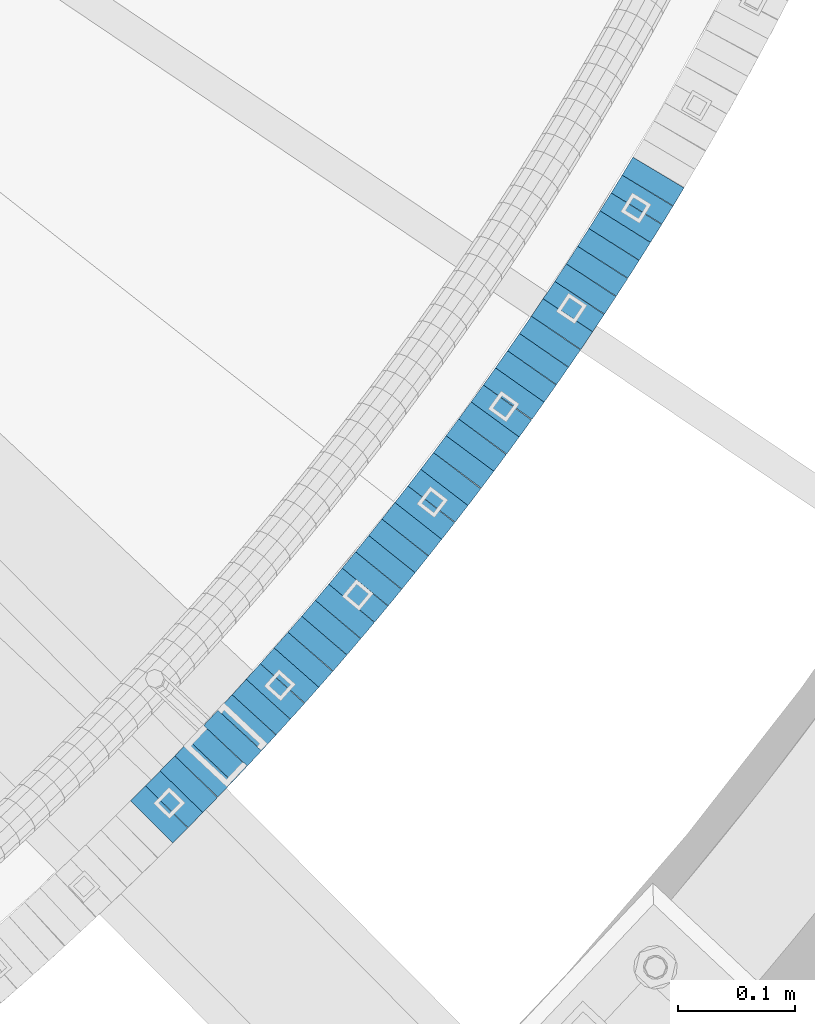
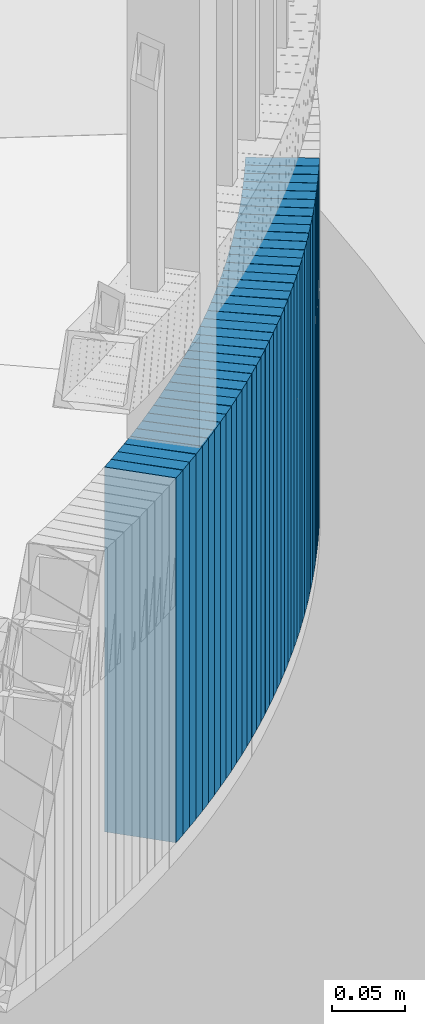
# One storey, part 905 of 975: 39 plates.
"""IFC2X3 building model written with IfcOpenShell, lengths in millimetres."""

from ifc_helpers import new_model, si_unit, frame, origin_with_axes, place, context, subcontext, project, spatial, faceted_brep, material, type_object, element, save


model = new_model("IFC2X3")

# Units and contexts
model_context = context("Model", 3, precision=1e-05, world=origin_with_axes())
body_context = subcontext(model_context, "Body", "Model", "MODEL_VIEW")
ifc_project = project(units=[si_unit("LENGTHUNIT", "METRE", prefix="MILLI"), si_unit("AREAUNIT", "SQUARE_METRE"), si_unit("VOLUMEUNIT", "CUBIC_METRE"), si_unit("MASSUNIT", "GRAM", prefix="KILO"), si_unit("TIMEUNIT", "SECOND"), si_unit("PLANEANGLEUNIT", "RADIAN"), si_unit("SOLIDANGLEUNIT", "STERADIAN"), si_unit("THERMODYNAMICTEMPERATUREUNIT", "DEGREE_CELSIUS"), si_unit("LUMINOUSINTENSITYUNIT", "LUMEN")], contexts=[model_context])

# Site, building, storey
site_placement = place(None, origin_with_axes())
site = spatial("IfcSite", under=ifc_project, at=site_placement, CompositionType="ELEMENT")
building_placement = place(site_placement, origin_with_axes())
building = spatial("IfcBuilding", under=site, at=building_placement, Name="Undefined", CompositionType="ELEMENT")
storey_placement = place(building_placement, origin_with_axes())
storey = spatial("IfcBuildingStorey", under=building, at=storey_placement, Name="Undefined", CompositionType="ELEMENT", Elevation=0.0)

# Plates
ifc_material = material(Name="STEEL/A36")
plate_type = type_object("IfcPlateType", PredefinedType="NOTDEFINED")
plate_1_placement = place(storey_placement, frame((36777.3519568225, 1386.64172835719, 2339.98750006771), z_axis=(-0.707106781186548, -0.707106781186548, 0.0), x_axis=(0.0, 0.0, 1.0)))
element("IfcPlate", 1, at=plate_1_placement, inside=storey, type_object=plate_type, material=ifc_material, Name="WALL", context=body_context, shape_type="Brep", body=[
    faceted_brep([(0.0, -25.3999999999724, -1.81898940354586e-11), (5.69999980926514, -25.3999999999432, 17.8213348388126), (5.69999980926514, 25.3999999999905, 17.8213348388708), (0.0, 25.3999999999869, 1.45519152283669e-11), (310.5, -25.3999999999432, 17.8213348388126), (310.5, 25.3999999999905, 17.8213348388708), (304.799987792969, -25.3999999999724, -1.81898940354586e-11), (304.799987792969, 25.3999999999869, 1.45519152283669e-11)], [[[0, 1, 2, 3]], [[1, 4, 5, 2]], [[4, 6, 7, 5]], [[6, 0, 3, 7]], [[5, 7, 3, 2]], [[6, 4, 1, 0]]]),
])
for number, where, z_axis, x_axis, name in (
    (2, (36790.0636498124, 1399.6559464257, 2334.28750006771), (-0.698672998973502, -0.715441150972862, 0.0), (0.0, 0.0, 1.0), "WALL"),
    (3, (36802.5636498098, 1412.45594642572, 2328.58750006771), (-0.698672998973502, -0.715441150972862, 0.0), (0.0, 0.0, 1.0), "WALL"),
):
    element("IfcPlate", number, at=place(storey_placement, frame(where, z_axis=z_axis, x_axis=x_axis)), inside=storey, type_object=plate_type, material=ifc_material, Name=name, context=body_context, shape_type="Brep", body=[
        faceted_brep([(0.0, -25.3999999999724, -1.81898940354586e-11), (5.69999980926514, -25.3999999999614, 17.8921775817616), (5.69999980926514, 25.400000000016, 17.8921775817726), (0.0, 25.3999999999869, 1.45519152283669e-11), (310.5, -25.3999999999614, 17.8921775817616), (310.5, 25.400000000016, 17.8921775817726), (304.799987792969, -25.3999999999724, -1.81898940354586e-11), (304.799987792969, 25.3999999999869, 1.45519152283669e-11)], [[[0, 1, 2, 3]], [[1, 4, 5, 2]], [[4, 6, 7, 5]], [[6, 0, 3, 7]], [[5, 7, 3, 2]], [[6, 4, 1, 0]]]),
    ])
plate_2_placement = place(storey_placement, frame((36815.0743782141, 1425.57432712152, 2322.78750006771), z_axis=(-0.690075333779924, -0.723737544769184, 0.0), x_axis=(0.0, 0.0, 1.0)))
element("IfcPlate", 4, at=plate_2_placement, inside=storey, type_object=plate_type, material=ifc_material, Name="WALL", context=body_context, shape_type="Brep", body=[
    faceted_brep([(0.0, -25.3999999999724, -1.81898940354586e-11), (5.80000019073486, -25.3999999999869, 17.8241405487097), (5.80000019073486, 25.3999999999432, 17.8241405486515), (0.0, 25.3999999999869, 1.45519152283669e-11), (310.600006103516, -25.3999999999869, 17.8241405487097), (310.600006103516, 25.3999999999432, 17.8241405486515), (304.799987792969, -25.3999999999724, -1.81898940354586e-11), (304.799987792969, 25.3999999999869, 1.45519152283669e-11)], [[[0, 1, 2, 3]], [[1, 4, 5, 2]], [[4, 6, 7, 5]], [[6, 0, 3, 7]], [[5, 7, 3, 2]], [[6, 4, 1, 0]]]),
])
plate_3_placement = place(storey_placement, frame((36827.4418272916, 1438.64534002369, 2317.08750006771), z_axis=(-0.68727955022236, -0.726393020235017, 0.0), x_axis=(0.0, 0.0, 1.0)))
element("IfcPlate", 5, at=plate_3_placement, inside=storey, type_object=plate_type, material=ifc_material, Name="WALL", context=body_context, shape_type="Brep", body=[
    faceted_brep([(0.0, -25.3999999999724, -1.81898940354586e-11), (5.69999980926514, -25.3999999999978, 17.9011173248218), (5.69999980926514, 25.4000000000087, 17.9011173248182), (0.0, 25.3999999999869, 1.45519152283669e-11), (310.5, -25.3999999999978, 17.9011173248218), (310.5, 25.4000000000087, 17.9011173248182), (304.799987792969, -25.3999999999724, -1.81898940354586e-11), (304.799987792969, 25.3999999999869, 1.45519152283669e-11)], [[[0, 1, 2, 3]], [[1, 4, 5, 2]], [[4, 6, 7, 5]], [[6, 0, 3, 7]], [[5, 7, 3, 2]], [[6, 4, 1, 0]]]),
])
plate_4_placement = place(storey_placement, frame((36839.684010914, 1451.79685192806, 2311.38750006771), z_axis=(-0.681314514625853, -0.731990800598025, 0.0), x_axis=(0.0, 0.0, 1.0)))
element("IfcPlate", 6, at=plate_4_placement, inside=storey, type_object=plate_type, material=ifc_material, Name="WALL", context=body_context, shape_type="Brep", body=[
    faceted_brep([(0.0, -25.3999999999724, -1.81898940354586e-11), (5.69999980926514, -25.3999999999542, 17.7609119415029), (5.69999980926514, 25.4000000000051, 17.7609119415283), (0.0, 25.3999999999869, 1.45519152283669e-11), (310.5, -25.3999999999542, 17.7609119415029), (310.5, 25.4000000000051, 17.7609119415283), (304.799987792969, -25.3999999999724, -1.81898940354586e-11), (304.799987792969, 25.3999999999869, 1.45519152283669e-11)], [[[0, 1, 2, 3]], [[1, 4, 5, 2]], [[4, 6, 7, 5]], [[6, 0, 3, 7]], [[5, 7, 3, 2]], [[6, 4, 1, 0]]]),
])
plate_5_placement = place(storey_placement, frame((36851.915159729, 1465.13883502595, 2305.68750006771), z_axis=(-0.675724628879609, -0.737154139868668, 0.0), x_axis=(0.0, 0.0, 1.0)))
element("IfcPlate", 7, at=plate_5_placement, inside=storey, type_object=plate_type, material=ifc_material, Name="WALL", context=body_context, shape_type="Brep", body=[
    faceted_brep([(0.0, -25.3999999999724, -1.81898940354586e-11), (5.69999980926514, -25.4000000000633, 17.9075393677485), (5.69999980926514, 25.3999999999905, 17.9075393676903), (0.0, 25.3999999999869, 1.45519152283669e-11), (310.5, -25.4000000000633, 17.9075393677485), (310.5, 25.3999999999905, 17.9075393676903), (304.799987792969, -25.3999999999724, -1.81898940354586e-11), (304.799987792969, 25.3999999999869, 1.45519152283669e-11)], [[[0, 1, 2, 3]], [[1, 4, 5, 2]], [[4, 6, 7, 5]], [[6, 0, 3, 7]], [[5, 7, 3, 2]], [[6, 4, 1, 0]]]),
])
plate_6_placement = place(storey_placement, frame((36863.9859224343, 1478.41635162711, 2299.88750006771), z_axis=(-0.672672794195408, -0.739940073214948, 0.0), x_axis=(0.0, 0.0, 1.0)))
element("IfcPlate", 8, at=plate_6_placement, inside=storey, type_object=plate_type, material=ifc_material, Name="WALL", context=body_context, shape_type="Brep", body=[
    faceted_brep([(0.0, -25.3999999999724, -1.81898940354586e-11), (5.80000019073486, -25.3999999999614, 17.8392829894583), (5.80000019073486, 25.3999999999578, 17.8392829895529), (0.0, 25.3999999999869, 1.45519152283669e-11), (310.600006103516, -25.3999999999614, 17.8392829894583), (310.600006103516, 25.3999999999578, 17.8392829895529), (304.799987792969, -25.3999999999724, -1.81898940354586e-11), (304.799987792969, 25.3999999999869, 1.45519152283669e-11)], [[[0, 1, 2, 3]], [[1, 4, 5, 2]], [[4, 6, 7, 5]], [[6, 0, 3, 7]], [[5, 7, 3, 2]], [[6, 4, 1, 0]]]),
])
plate_7_placement = place(storey_placement, frame((36876.0499497796, 1491.78704793645, 2294.18750006771), z_axis=(-0.669889474924749, -0.742460834916593, 0.0), x_axis=(0.0, 0.0, 1.0)))
element("IfcPlate", 9, at=plate_7_placement, inside=storey, type_object=plate_type, material=ifc_material, Name="WALL", context=body_context, shape_type="Brep", body=[
    faceted_brep([(0.0, -25.3999999999724, -1.81898940354586e-11), (5.69999980926514, -25.4000000000633, 17.9075393677485), (5.69999980926514, 25.3999999999905, 17.9075393676903), (0.0, 25.3999999999869, 1.45519152283669e-11), (310.5, -25.4000000000633, 17.9075393677485), (310.5, 25.3999999999905, 17.9075393676903), (304.799987792969, -25.3999999999724, -1.81898940354586e-11), (304.799987792969, 25.3999999999869, 1.45519152283669e-11)], [[[0, 1, 2, 3]], [[1, 4, 5, 2]], [[4, 6, 7, 5]], [[6, 0, 3, 7]], [[5, 7, 3, 2]], [[6, 4, 1, 0]]]),
])
plate_8_placement = place(storey_placement, frame((36888.0539227053, 1505.4158792494, 2288.48750006771), z_axis=(-0.660880368115947, -0.750491265131667, 0.0), x_axis=(0.0, 0.0, 1.0)))
element("IfcPlate", 10, at=plate_8_placement, inside=storey, type_object=plate_type, material=ifc_material, Name="WALL", context=body_context, shape_type="Brep", body=[
    faceted_brep([(0.0, -25.3999999999724, -1.81898940354586e-11), (5.69999980926514, -25.4000000000196, 17.8538513183848), (5.69999980926514, 25.4000000000415, 17.8538513183157), (0.0, 25.3999999999869, 1.45519152283669e-11), (310.5, -25.4000000000196, 17.8538513183848), (310.5, 25.4000000000415, 17.8538513183157), (304.799987792969, -25.3999999999724, -1.81898940354586e-11), (304.799987792969, 25.3999999999869, 1.45519152283669e-11)], [[[0, 1, 2, 3]], [[1, 4, 5, 2]], [[4, 6, 7, 5]], [[6, 0, 3, 7]], [[5, 7, 3, 2]], [[6, 4, 1, 0]]]),
])
plate_9_placement = place(storey_placement, frame((36899.8539227035, 1518.81587924938, 2282.68750006771), z_axis=(-0.660880368115947, -0.750491265131667, 0.0), x_axis=(0.0, 0.0, 1.0)))
element("IfcPlate", 11, at=plate_9_placement, inside=storey, type_object=plate_type, material=ifc_material, Name="WALL", context=body_context, shape_type="Brep", body=[
    faceted_brep([(0.0, -25.3999999999724, -1.81898940354586e-11), (5.80000019073486, -25.4000000000306, 17.853010177645), (5.80000019073486, 25.3999999999578, 17.8530101776596), (0.0, 25.3999999999869, 1.45519152283669e-11), (310.600006103516, -25.4000000000306, 17.853010177645), (310.600006103516, 25.3999999999578, 17.8530101776596), (304.799987792969, -25.3999999999724, -1.81898940354586e-11), (304.799987792969, 25.3999999999869, 1.45519152283669e-11)], [[[0, 1, 2, 3]], [[1, 4, 5, 2]], [[4, 6, 7, 5]], [[6, 0, 3, 7]], [[5, 7, 3, 2]], [[6, 4, 1, 0]]]),
])
plate_10_placement = place(storey_placement, frame((36911.7465485518, 1532.63718790625, 2276.98750006771), z_axis=(-0.652167428860609, -0.758074959837972, 0.0), x_axis=(0.0, 0.0, 1.0)))
element("IfcPlate", 12, at=plate_10_placement, inside=storey, type_object=plate_type, material=ifc_material, Name="WALL", context=body_context, shape_type="Brep", body=[
    faceted_brep([(0.0, -25.3999999999724, -1.81898940354586e-11), (5.69999980926514, -25.3999999999542, 17.9401779173968), (5.69999980926514, 25.3999999999924, 17.9401779175023), (0.0, 25.3999999999869, 1.45519152283669e-11), (310.5, -25.3999999999542, 17.9401779173968), (310.5, 25.3999999999924, 17.9401779175023), (304.799987792969, -25.3999999999724, -1.81898940354586e-11), (304.799987792969, 25.3999999999869, 1.45519152283669e-11)], [[[0, 1, 2, 3]], [[1, 4, 5, 2]], [[4, 6, 7, 5]], [[6, 0, 3, 7]], [[5, 7, 3, 2]], [[6, 4, 1, 0]]]),
])
plate_11_placement = place(storey_placement, frame((36923.4166269546, 1546.31899680664, 2271.28750006771), z_axis=(-0.648946606014645, -0.760833952017175, 0.0), x_axis=(0.0, 0.0, 1.0)))
element("IfcPlate", 13, at=plate_11_placement, inside=storey, type_object=plate_type, material=ifc_material, Name="WALL", context=body_context, shape_type="Brep", body=[
    faceted_brep([(0.0, -25.3999999999724, -1.81898940354586e-11), (5.69999980926514, -25.3999999999687, 17.8807163238307), (5.69999980926514, 25.400000000016, 17.880716323838), (0.0, 25.3999999999869, 1.45519152283669e-11), (310.5, -25.3999999999687, 17.8807163238307), (310.5, 25.400000000016, 17.880716323838), (304.799987792969, -25.3999999999724, -1.81898940354586e-11), (304.799987792969, 25.3999999999869, 1.45519152283669e-11)], [[[0, 1, 2, 3]], [[1, 4, 5, 2]], [[4, 6, 7, 5]], [[6, 0, 3, 7]], [[5, 7, 3, 2]], [[6, 4, 1, 0]]]),
])
plate_12_placement = place(storey_placement, frame((36935.0459418871, 1560.17182314427, 2265.48750006771), z_axis=(-0.642929821078935, -0.765925091094037, 0.0), x_axis=(0.0, 0.0, 1.0)))
element("IfcPlate", 14, at=plate_12_placement, inside=storey, type_object=plate_type, material=ifc_material, Name="WALL", context=body_context, shape_type="Brep", body=[
    faceted_brep([(0.0, -25.3999999999724, -1.81898940354586e-11), (5.80000019073486, -25.4000000000451, 17.8891029358201), (5.80000019073486, 25.4000000000087, 17.8891029357856), (0.0, 25.3999999999869, 1.45519152283669e-11), (310.600006103516, -25.4000000000451, 17.8891029358201), (310.600006103516, 25.4000000000087, 17.8891029357856), (304.799987792969, -25.3999999999724, -1.81898940354586e-11), (304.799987792969, 25.3999999999869, 1.45519152283669e-11)], [[[0, 1, 2, 3]], [[1, 4, 5, 2]], [[4, 6, 7, 5]], [[6, 0, 3, 7]], [[5, 7, 3, 2]], [[6, 4, 1, 0]]]),
])
plate_13_placement = place(storey_placement, frame((36946.5159415609, 1573.95557886613, 2259.78750006771), z_axis=(-0.639632351715919, -0.768680983658606, 0.0), x_axis=(0.0, 0.0, 1.0)))
element("IfcPlate", 15, at=plate_13_placement, inside=storey, type_object=plate_type, material=ifc_material, Name="WALL", context=body_context, shape_type="Brep", body=[
    faceted_brep([(0.0, -25.3999999999724, -1.81898940354586e-11), (5.69999980926514, -25.3999999999432, 17.8213348388126), (5.69999980926514, 25.3999999999905, 17.8213348388708), (0.0, 25.3999999999869, 1.45519152283669e-11), (310.5, -25.3999999999432, 17.8213348388126), (310.5, 25.3999999999905, 17.8213348388708), (304.799987792969, -25.3999999999724, -1.81898940354586e-11), (304.799987792969, 25.3999999999869, 1.45519152283669e-11)], [[[0, 1, 2, 3]], [[1, 4, 5, 2]], [[4, 6, 7, 5]], [[6, 0, 3, 7]], [[5, 7, 3, 2]], [[6, 4, 1, 0]]]),
])
plate_14_placement = place(storey_placement, frame((36958.031060828, 1587.99492942279, 2253.98750006771), z_axis=(-0.634146109323957, -0.773213238395003, 0.0), x_axis=(0.0, 0.0, 1.0)))
element("IfcPlate", 16, at=plate_14_placement, inside=storey, type_object=plate_type, material=ifc_material, Name="WALL", context=body_context, shape_type="Brep", body=[
    faceted_brep([(0.0, -25.3999999999724, -1.81898940354586e-11), (5.80000019073486, -25.3999999999505, 17.9788761138298), (5.80000019073486, 25.4000000000196, 17.9788761138625), (0.0, 25.3999999999869, 1.45519152283669e-11), (310.600006103516, -25.3999999999505, 17.9788761138298), (310.600006103516, 25.4000000000196, 17.9788761138625), (304.799987792969, -25.3999999999724, -1.81898940354586e-11), (304.799987792969, 25.3999999999869, 1.45519152283669e-11)], [[[0, 1, 2, 3]], [[1, 4, 5, 2]], [[4, 6, 7, 5]], [[6, 0, 3, 7]], [[5, 7, 3, 2]], [[6, 4, 1, 0]]]),
])
plate_15_placement = place(storey_placement, frame((36969.3698627731, 1602.06567341649, 2248.28750006771), z_axis=(-0.627423904848963, -0.77867788181255, 0.0), x_axis=(0.0, 0.0, 1.0)))
element("IfcPlate", 17, at=plate_15_placement, inside=storey, type_object=plate_type, material=ifc_material, Name="WALL", context=body_context, shape_type="Brep", body=[
    faceted_brep([(0.0, -25.3999999999724, -1.81898940354586e-11), (5.69999980926514, -25.4000000000196, 17.8538513183848), (5.69999980926514, 25.4000000000415, 17.8538513183157), (0.0, 25.3999999999869, 1.45519152283669e-11), (310.5, -25.4000000000196, 17.8538513183848), (310.5, 25.4000000000415, 17.8538513183157), (304.799987792969, -25.3999999999724, -1.81898940354586e-11), (304.799987792969, 25.3999999999869, 1.45519152283669e-11)], [[[0, 1, 2, 3]], [[1, 4, 5, 2]], [[4, 6, 7, 5]], [[6, 0, 3, 7]], [[5, 7, 3, 2]], [[6, 4, 1, 0]]]),
])
plate_16_placement = place(storey_placement, frame((36980.6255123255, 1616.1349863794, 2242.58750006771), z_axis=(-0.624695048042231, -0.780868809052785, 0.0), x_axis=(0.0, 0.0, 1.0)))
element("IfcPlate", 18, at=plate_16_placement, inside=storey, type_object=plate_type, material=ifc_material, Name="WALL", context=body_context, shape_type="Brep", body=[
    faceted_brep([(0.0, -25.3999999999724, -1.81898940354586e-11), (5.69999980926514, -25.3999999999896, 17.9334888457815), (5.69999980926514, 25.3999999999869, 17.9334888458907), (0.0, 25.3999999999869, 1.45519152283669e-11), (310.5, -25.3999999999896, 17.9334888457815), (310.5, 25.3999999999869, 17.9334888458907), (304.799987792969, -25.3999999999724, -1.81898940354586e-11), (304.799987792969, 25.3999999999869, 1.45519152283669e-11)], [[[0, 1, 2, 3]], [[1, 4, 5, 2]], [[4, 6, 7, 5]], [[6, 0, 3, 7]], [[5, 7, 3, 2]], [[6, 4, 1, 0]]]),
])
for number, where, z_axis, x_axis, name in (
    (19, (36991.8491866882, 1630.39082660029, 2236.78750006771), (-0.618559606278717, -0.785737878354047, 0.0), (0.0, 0.0, 1.0), "WALL"),
    (20, (37002.9491866905, 1644.49082660041, 2230.98750006771), (-0.618559606278717, -0.785737878354047, 0.0), (0.0, 0.0, 1.0), "WALL"),
):
    element("IfcPlate", number, at=place(storey_placement, frame(where, z_axis=z_axis, x_axis=x_axis)), inside=storey, type_object=plate_type, material=ifc_material, Name=name, context=body_context, shape_type="Brep", body=[
        faceted_brep([(0.0, -25.3999999999724, -1.81898940354586e-11), (5.80000019073486, -25.3999999999614, 17.9424076079595), (5.80000019073486, 25.3999999999978, 17.9424076080322), (0.0, 25.3999999999869, 1.45519152283669e-11), (310.600006103516, -25.3999999999614, 17.9424076079595), (310.600006103516, 25.3999999999978, 17.9424076080322), (304.799987792969, -25.3999999999724, -1.81898940354586e-11), (304.799987792969, 25.3999999999869, 1.45519152283669e-11)], [[[0, 1, 2, 3]], [[1, 4, 5, 2]], [[4, 6, 7, 5]], [[6, 0, 3, 7]], [[5, 7, 3, 2]], [[6, 4, 1, 0]]]),
    ])
for number, where, z_axis, x_axis, name in (
    (21, (37014.0399076218, 1658.93616685212, 2225.28750006771), (-0.60890054125397, -0.793246576330855, 0.0), (0.0, 0.0, 1.0), "WALL"),
    (22, (37024.9399076244, 1673.13616685225, 2219.58750006771), (-0.60890054125397, -0.793246576330855, 0.0), (0.0, 0.0, 1.0), "WALL"),
):
    element("IfcPlate", number, at=place(storey_placement, frame(where, z_axis=z_axis, x_axis=x_axis)), inside=storey, type_object=plate_type, material=ifc_material, Name=name, context=body_context, shape_type="Brep", body=[
        faceted_brep([(0.0, -25.3999999999724, -1.81898940354586e-11), (5.69999980926514, -25.3999999999978, 17.9011173248218), (5.69999980926514, 25.4000000000087, 17.9011173248182), (0.0, 25.3999999999869, 1.45519152283669e-11), (310.5, -25.3999999999978, 17.9011173248218), (310.5, 25.4000000000087, 17.9011173248182), (304.799987792969, -25.3999999999724, -1.81898940354586e-11), (304.799987792969, 25.3999999999869, 1.45519152283669e-11)], [[[0, 1, 2, 3]], [[1, 4, 5, 2]], [[4, 6, 7, 5]], [[6, 0, 3, 7]], [[5, 7, 3, 2]], [[6, 4, 1, 0]]]),
    ])
plate_17_placement = place(storey_placement, frame((37035.8792017443, 1687.85300438162, 2213.78750006771), z_axis=(-0.596426622779436, -0.802667604703165, 0.0), x_axis=(0.0, 0.0, 1.0)))
element("IfcPlate", 23, at=plate_17_placement, inside=storey, type_object=plate_type, material=ifc_material, Name="WALL", context=body_context, shape_type="Brep", body=[
    faceted_brep([(0.0, -25.3999999999724, -1.81898940354586e-11), (5.80000019073486, -25.3999999999614, 17.9424076079595), (5.80000019073486, 25.3999999999978, 17.9424076080322), (0.0, 25.3999999999869, 1.45519152283669e-11), (310.600006103516, -25.3999999999614, 17.9424076079595), (310.600006103516, 25.3999999999978, 17.9424076080322), (304.799987792969, -25.3999999999724, -1.81898940354586e-11), (304.799987792969, 25.3999999999869, 1.45519152283669e-11)], [[[0, 1, 2, 3]], [[1, 4, 5, 2]], [[4, 6, 7, 5]], [[6, 0, 3, 7]], [[5, 7, 3, 2]], [[6, 4, 1, 0]]]),
])
plate_18_placement = place(storey_placement, frame((37046.5284978949, 1702.08500489001, 2208.08750006771), z_axis=(-0.59910376812092, -0.800671390161603, 0.0), x_axis=(0.0, 0.0, 1.0)))
element("IfcPlate", 24, at=plate_18_placement, inside=storey, type_object=plate_type, material=ifc_material, Name="WALL", context=body_context, shape_type="Brep", body=[
    faceted_brep([(0.0, -25.3999999999724, -1.81898940354586e-11), (5.69999980926514, -25.4000000000378, 17.8639297485788), (5.69999980926514, 25.3999999999833, 17.8639297485533), (0.0, 25.3999999999869, 1.45519152283669e-11), (310.5, -25.4000000000378, 17.8639297485788), (310.5, 25.3999999999833, 17.8639297485533), (304.799987792969, -25.3999999999724, -1.81898940354586e-11), (304.799987792969, 25.3999999999869, 1.45519152283669e-11)], [[[0, 1, 2, 3]], [[1, 4, 5, 2]], [[4, 6, 7, 5]], [[6, 0, 3, 7]], [[5, 7, 3, 2]], [[6, 4, 1, 0]]]),
])
plate_19_placement = place(storey_placement, frame((37057.2965877691, 1716.81227385968, 2202.28750006771), z_axis=(-0.590156170888652, -0.807289101847686, 0.0), x_axis=(0.0, 0.0, 1.0)))
element("IfcPlate", 25, at=plate_19_placement, inside=storey, type_object=plate_type, material=ifc_material, Name="WALL", context=body_context, shape_type="Brep", body=[
    faceted_brep([(0.0, -25.3999999999724, -1.81898940354586e-11), (5.80000019073486, -25.399999999976, 17.9610691070338), (5.80000019073486, 25.4000000000269, 17.9610691070338), (0.0, 25.3999999999869, 1.45519152283669e-11), (310.600006103516, -25.399999999976, 17.9610691070338), (310.600006103516, 25.4000000000269, 17.9610691070338), (304.799987792969, -25.3999999999724, -1.81898940354586e-11), (304.799987792969, 25.3999999999869, 1.45519152283669e-11)], [[[0, 1, 2, 3]], [[1, 4, 5, 2]], [[4, 6, 7, 5]], [[6, 0, 3, 7]], [[5, 7, 3, 2]], [[6, 4, 1, 0]]]),
])
plate_20_placement = place(storey_placement, frame((37067.8148358521, 1731.23726780603, 2196.58750006771), z_axis=(-0.589172157259019, -0.808007530355228, 0.0), x_axis=(0.0, 0.0, 1.0)))
element("IfcPlate", 26, at=plate_20_placement, inside=storey, type_object=plate_type, material=ifc_material, Name="WALL", context=body_context, shape_type="Brep", body=[
    faceted_brep([(0.0, -25.3999999999724, -1.81898940354586e-11), (5.69999980926514, -25.3999999999432, 17.8213348388126), (5.69999980926514, 25.3999999999905, 17.8213348388708), (0.0, 25.3999999999869, 1.45519152283669e-11), (310.5, -25.3999999999432, 17.8213348388126), (310.5, 25.3999999999905, 17.8213348388708), (304.799987792969, -25.3999999999724, -1.81898940354586e-11), (304.799987792969, 25.3999999999869, 1.45519152283669e-11)], [[[0, 1, 2, 3]], [[1, 4, 5, 2]], [[4, 6, 7, 5]], [[6, 0, 3, 7]], [[5, 7, 3, 2]], [[6, 4, 1, 0]]]),
])
plate_21_placement = place(storey_placement, frame((37078.346367232, 1746.16006912075, 2190.88750006771), z_axis=(-0.576463444084067, -0.817122939119161, 0.0), x_axis=(0.0, 0.0, 1.0)))
element("IfcPlate", 27, at=plate_21_placement, inside=storey, type_object=plate_type, material=ifc_material, Name="WALL", context=body_context, shape_type="Brep", body=[
    faceted_brep([(0.0, -25.3999999999724, -1.81898940354586e-11), (5.69999980926514, -25.3999999999469, 17.8731651305425), (5.69999980926514, 25.3999999999869, 17.8731651306334), (0.0, 25.3999999999869, 1.45519152283669e-11), (310.5, -25.3999999999469, 17.8731651305425), (310.5, 25.3999999999869, 17.8731651306334), (304.799987792969, -25.3999999999724, -1.81898940354586e-11), (304.799987792969, 25.3999999999869, 1.45519152283669e-11)], [[[0, 1, 2, 3]], [[1, 4, 5, 2]], [[4, 6, 7, 5]], [[6, 0, 3, 7]], [[5, 7, 3, 2]], [[6, 4, 1, 0]]]),
])
plate_22_placement = place(storey_placement, frame((37088.6463672293, 1760.7600691208, 2185.08750006771), z_axis=(-0.576463444084067, -0.817122939119161, 0.0), x_axis=(0.0, 0.0, 1.0)))
element("IfcPlate", 28, at=plate_22_placement, inside=storey, type_object=plate_type, material=ifc_material, Name="WALL", context=body_context, shape_type="Brep", body=[
    faceted_brep([(0.0, -25.3999999999724, -1.81898940354586e-11), (5.80000019073486, -25.3999999999705, 17.873443603421), (5.80000019073486, 25.3999999999924, 17.8734436035338), (0.0, 25.3999999999869, 1.45519152283669e-11), (310.600006103516, -25.3999999999705, 17.873443603421), (310.600006103516, 25.3999999999924, 17.8734436035338), (304.799987792969, -25.3999999999724, -1.81898940354586e-11), (304.799987792969, 25.3999999999869, 1.45519152283669e-11)], [[[0, 1, 2, 3]], [[1, 4, 5, 2]], [[4, 6, 7, 5]], [[6, 0, 3, 7]], [[5, 7, 3, 2]], [[6, 4, 1, 0]]]),
])
plate_23_placement = place(storey_placement, frame((37098.9597826693, 1775.62216928447, 2179.38750006771), z_axis=(-0.570081547875678, -0.821588113820831, 0.0), x_axis=(0.0, 0.0, 1.0)))
element("IfcPlate", 29, at=plate_23_placement, inside=storey, type_object=plate_type, material=ifc_material, Name="WALL", context=body_context, shape_type="Brep", body=[
    faceted_brep([(0.0, -25.3999999999724, -1.81898940354586e-11), (5.69999980926514, -25.3999999999614, 17.8921775817616), (5.69999980926514, 25.400000000016, 17.8921775817726), (0.0, 25.3999999999869, 1.45519152283669e-11), (310.5, -25.3999999999614, 17.8921775817616), (310.5, 25.400000000016, 17.8921775817726), (304.799987792969, -25.3999999999724, -1.81898940354586e-11), (304.799987792969, 25.3999999999869, 1.45519152283669e-11)], [[[0, 1, 2, 3]], [[1, 4, 5, 2]], [[4, 6, 7, 5]], [[6, 0, 3, 7]], [[5, 7, 3, 2]], [[6, 4, 1, 0]]]),
])
plate_24_placement = place(storey_placement, frame((37109.1262638944, 1790.41845319118, 2173.68750006771), z_axis=(-0.566290842895315, -0.824205484847628, 0.0), x_axis=(0.0, 0.0, 1.0)))
element("IfcPlate", 30, at=plate_24_placement, inside=storey, type_object=plate_type, material=ifc_material, Name="WALL", context=body_context, shape_type="Brep", body=[
    faceted_brep([(0.0, -25.3999999999724, -1.81898940354586e-11), (5.69999980926514, -25.3999999999651, 17.8440475463649), (5.69999980926514, 25.3999999999942, 17.8440475463904), (0.0, 25.3999999999869, 1.45519152283669e-11), (310.5, -25.3999999999651, 17.8440475463649), (310.5, 25.3999999999942, 17.8440475463904), (304.799987792969, -25.3999999999724, -1.81898940354586e-11), (304.799987792969, 25.3999999999869, 1.45519152283669e-11)], [[[0, 1, 2, 3]], [[1, 4, 5, 2]], [[4, 6, 7, 5]], [[6, 0, 3, 7]], [[5, 7, 3, 2]], [[6, 4, 1, 0]]]),
])
plate_25_placement = place(storey_placement, frame((37119.2818683271, 1805.54759379348, 2167.88750006771), z_axis=(-0.557269558884145, -0.830331643827375, 0.0), x_axis=(0.0, 0.0, 1.0)))
element("IfcPlate", 31, at=plate_25_placement, inside=storey, type_object=plate_type, material=ifc_material, Name="WALL", context=body_context, shape_type="Brep", body=[
    faceted_brep([(0.0, -25.3999999999724, -1.81898940354586e-11), (5.80000019073486, -25.3999999999614, 17.9424076079595), (5.80000019073486, 25.3999999999978, 17.9424076080322), (0.0, 25.3999999999869, 1.45519152283669e-11), (310.600006103516, -25.3999999999614, 17.9424076079595), (310.600006103516, 25.3999999999978, 17.9424076080322), (304.799987792969, -25.3999999999724, -1.81898940354586e-11), (304.799987792969, 25.3999999999869, 1.45519152283669e-11)], [[[0, 1, 2, 3]], [[1, 4, 5, 2]], [[4, 6, 7, 5]], [[6, 0, 3, 7]], [[5, 7, 3, 2]], [[6, 4, 1, 0]]]),
])
plate_26_placement = place(storey_placement, frame((37129.2035503661, 1820.37995362878, 2162.18750006771), z_axis=(-0.555995550084051, -0.831185267125648, 0.0), x_axis=(0.0, 0.0, 1.0)))
element("IfcPlate", 32, at=plate_26_placement, inside=storey, type_object=plate_type, material=ifc_material, Name="WALL", context=body_context, shape_type="Brep", body=[
    faceted_brep([(0.0, -25.3999999999724, -1.81898940354586e-11), (5.69999980926514, -25.4000000000306, 17.8058986664291), (5.69999980926514, 25.4000000000415, 17.80589866632), (0.0, 25.3999999999869, 1.45519152283669e-11), (310.5, -25.4000000000306, 17.8058986664291), (310.5, 25.4000000000415, 17.80589866632), (304.799987792969, -25.3999999999724, -1.81898940354586e-11), (304.799987792969, 25.3999999999869, 1.45519152283669e-11)], [[[0, 1, 2, 3]], [[1, 4, 5, 2]], [[4, 6, 7, 5]], [[6, 0, 3, 7]], [[5, 7, 3, 2]], [[6, 4, 1, 0]]]),
])
plate_27_placement = place(storey_placement, frame((37139.1127592425, 1835.44459739169, 2156.48750006771), z_axis=(-0.549513512175916, -0.835484829267468, 0.0), x_axis=(0.0, 0.0, 1.0)))
element("IfcPlate", 33, at=plate_27_placement, inside=storey, type_object=plate_type, material=ifc_material, Name="WALL", context=body_context, shape_type="Brep", body=[
    faceted_brep([(0.0, -25.3999999999724, -1.81898940354586e-11), (5.69999980926514, -25.3999999999724, 17.833955764745), (5.69999980926514, 25.3999999999905, 17.8339557647923), (0.0, 25.3999999999869, 1.45519152283669e-11), (310.5, -25.3999999999724, 17.833955764745), (310.5, 25.3999999999905, 17.8339557647923), (304.799987792969, -25.3999999999724, -1.81898940354586e-11), (304.799987792969, 25.3999999999869, 1.45519152283669e-11)], [[[0, 1, 2, 3]], [[1, 4, 5, 2]], [[4, 6, 7, 5]], [[6, 0, 3, 7]], [[5, 7, 3, 2]], [[6, 4, 1, 0]]]),
])
plate_28_placement = place(storey_placement, frame((37148.920340674, 1850.60955444879, 2150.78750006771), z_axis=(-0.543019139851262, -0.839720318770003, 0.0), x_axis=(0.0, 0.0, 1.0)))
element("IfcPlate", 34, at=plate_28_placement, inside=storey, type_object=plate_type, material=ifc_material, Name="WALL", context=body_context, shape_type="Brep", body=[
    faceted_brep([(0.0, -25.3999999999724, -1.81898940354586e-11), (5.69999980926514, -25.4000000000378, 17.8639297485788), (5.69999980926514, 25.3999999999833, 17.8639297485533), (0.0, 25.3999999999869, 1.45519152283669e-11), (310.5, -25.4000000000378, 17.8639297485788), (310.5, 25.3999999999833, 17.8639297485533), (304.799987792969, -25.3999999999724, -1.81898940354586e-11), (304.799987792969, 25.3999999999869, 1.45519152283669e-11)], [[[0, 1, 2, 3]], [[1, 4, 5, 2]], [[4, 6, 7, 5]], [[6, 0, 3, 7]], [[5, 7, 3, 2]], [[6, 4, 1, 0]]]),
])
plate_29_placement = place(storey_placement, frame((37158.6262895108, 1865.87478952682, 2144.98750006771), z_axis=(-0.536513821821304, -0.843891532718926, 0.0), x_axis=(0.0, 0.0, 1.0)))
element("IfcPlate", 35, at=plate_29_placement, inside=storey, type_object=plate_type, material=ifc_material, Name="WALL", context=body_context, shape_type="Brep", body=[
    faceted_brep([(0.0, -25.3999999999724, -1.81898940354586e-11), (5.80000019073486, -25.4000000000451, 17.8891029358201), (5.80000019073486, 25.4000000000087, 17.8891029357856), (0.0, 25.3999999999869, 1.45519152283669e-11), (310.600006103516, -25.4000000000451, 17.8891029358201), (310.600006103516, 25.4000000000087, 17.8891029357856), (304.799987792969, -25.3999999999724, -1.81898940354586e-11), (304.799987792969, 25.3999999999869, 1.45519152283669e-11)], [[[0, 1, 2, 3]], [[1, 4, 5, 2]], [[4, 6, 7, 5]], [[6, 0, 3, 7]], [[5, 7, 3, 2]], [[6, 4, 1, 0]]]),
])
plate_30_placement = place(storey_placement, frame((37168.1905126453, 1881.07633684927, 2139.28750006771), z_axis=(-0.532515895741409, -0.846420002588978, 0.0), x_axis=(0.0, 0.0, 1.0)))
element("IfcPlate", 36, at=plate_30_placement, inside=storey, type_object=plate_type, material=ifc_material, Name="WALL", context=body_context, shape_type="Brep", body=[
    faceted_brep([(0.0, -25.3999999999724, -1.81898940354586e-11), (5.69999980926514, -25.3999999999651, 17.8440475463649), (5.69999980926514, 25.3999999999942, 17.8440475463904), (0.0, 25.3999999999869, 1.45519152283669e-11), (310.5, -25.3999999999651, 17.8440475463649), (310.5, 25.3999999999942, 17.8440475463904), (304.799987792969, -25.3999999999724, -1.81898940354586e-11), (304.799987792969, 25.3999999999869, 1.45519152283669e-11)], [[[0, 1, 2, 3]], [[1, 4, 5, 2]], [[4, 6, 7, 5]], [[6, 0, 3, 7]], [[5, 7, 3, 2]], [[6, 4, 1, 0]]]),
])
plate_31_placement = place(storey_placement, frame((37177.7306014986, 1896.34026752513, 2133.58750006771), z_axis=(-0.529998940003178, -0.84799830400509, 0.0), x_axis=(0.0, 0.0, 1.0)))
element("IfcPlate", 37, at=plate_31_placement, inside=storey, type_object=plate_type, material=ifc_material, Name="WALL", context=body_context, shape_type="Brep", body=[
    faceted_brep([(0.0, -25.3999999999724, -1.81898940354586e-11), (5.69999980926514, -25.3999999999724, 17.9212169646999), (5.69999980926514, 25.3999999999651, 17.9212169647544), (0.0, 25.3999999999869, 1.45519152283669e-11), (310.5, -25.3999999999724, 17.9212169646999), (310.5, 25.3999999999651, 17.9212169647544), (304.799987792969, -25.3999999999724, -1.81898940354586e-11), (304.799987792969, 25.3999999999869, 1.45519152283669e-11)], [[[0, 1, 2, 3]], [[1, 4, 5, 2]], [[4, 6, 7, 5]], [[6, 0, 3, 7]], [[5, 7, 3, 2]], [[6, 4, 1, 0]]]),
])
plate_32_placement = place(storey_placement, frame((37187.157753083, 1911.74588078058, 2127.88750006771), z_axis=(-0.52190392994789, -0.853004271914829, 0.0), x_axis=(0.0, 0.0, 1.0)))
element("IfcPlate", 38, at=plate_32_placement, inside=storey, type_object=plate_type, material=ifc_material, Name="WALL", context=body_context, shape_type="Brep", body=[
    faceted_brep([(0.0, -25.3999999999724, -1.81898940354586e-11), (5.69999980926514, -25.3999999999432, 17.8213348388126), (5.69999980926514, 25.3999999999905, 17.8213348388708), (0.0, 25.3999999999869, 1.45519152283669e-11), (310.5, -25.3999999999432, 17.8213348388126), (310.5, 25.3999999999905, 17.8213348388708), (304.799987792969, -25.3999999999724, -1.81898940354586e-11), (304.799987792969, 25.3999999999869, 1.45519152283669e-11)], [[[0, 1, 2, 3]], [[1, 4, 5, 2]], [[4, 6, 7, 5]], [[6, 0, 3, 7]], [[5, 7, 3, 2]], [[6, 4, 1, 0]]]),
])
plate_33_placement = place(storey_placement, frame((37196.4592013485, 1927.21313195499, 2122.08750006771), z_axis=(-0.515319238044372, -0.856998298073787, 0.0), x_axis=(0.0, 0.0, 1.0)))
element("IfcPlate", 39, at=plate_33_placement, inside=storey, type_object=plate_type, material=ifc_material, Name="WALL", context=body_context, shape_type="Brep", body=[
    faceted_brep([(0.0, -25.3999999999724, -1.81898940354586e-11), (5.80000019073486, -25.4000000000306, 17.853010177645), (5.80000019073486, 25.3999999999578, 17.8530101776596), (0.0, 25.3999999999869, 1.45519152283669e-11), (310.600006103516, -25.4000000000306, 17.853010177645), (310.600006103516, 25.3999999999578, 17.8530101776596), (304.799987792969, -25.3999999999724, -1.81898940354586e-11), (304.799987792969, 25.3999999999869, 1.45519152283669e-11)], [[[0, 1, 2, 3]], [[1, 4, 5, 2]], [[4, 6, 7, 5]], [[6, 0, 3, 7]], [[5, 7, 3, 2]], [[6, 4, 1, 0]]]),
])

save(model, "model.ifc")
